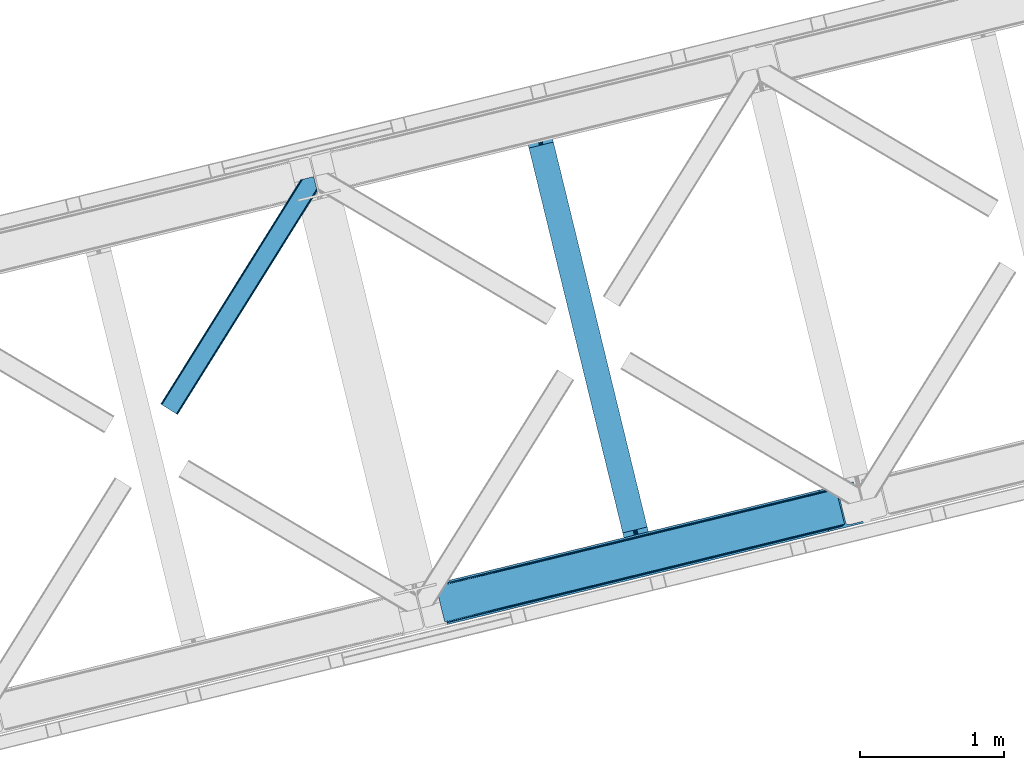
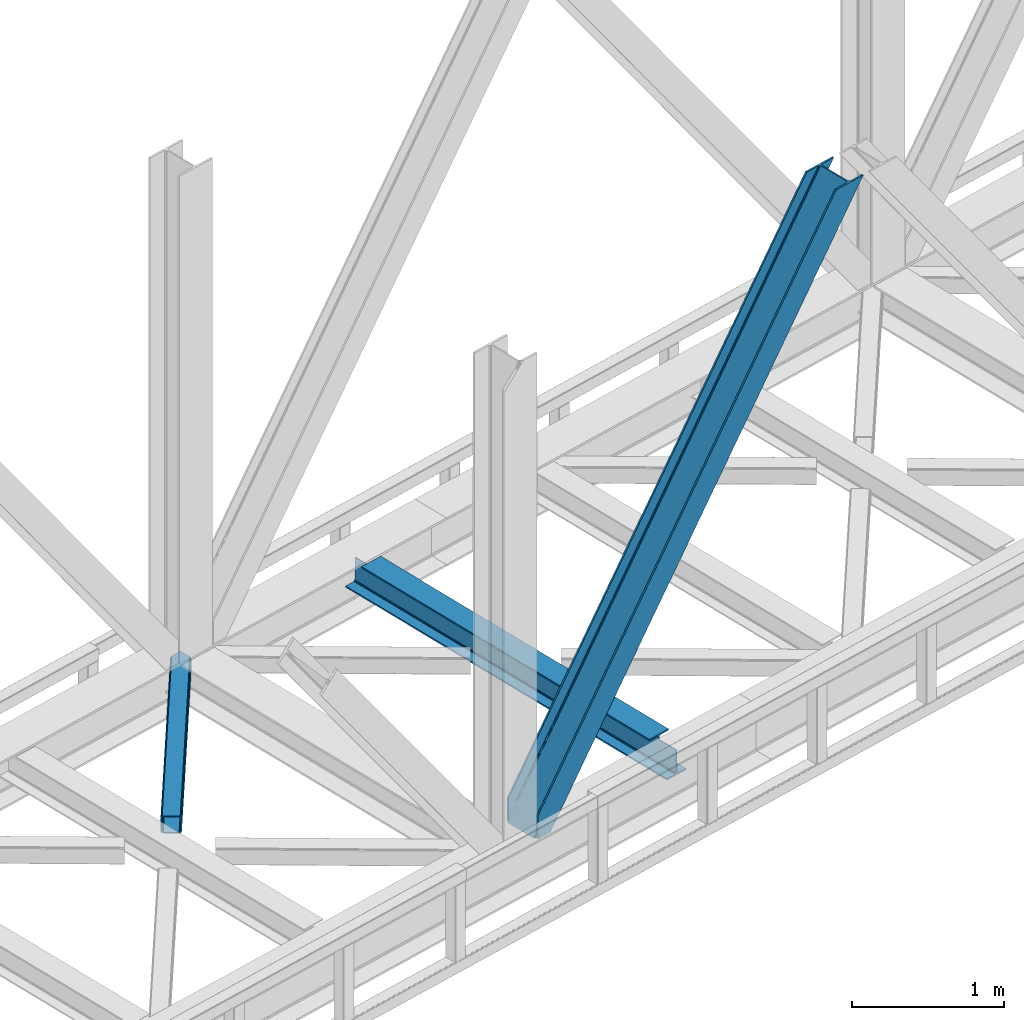
# One storey, part 63 of 92: 2 members, 1 beam.
"""IFC4 building model written with IfcOpenShell, lengths in millimetres."""

import ifcopenshell
import ifcopenshell.guid

model = None  # the IFC model being written
_history = None  # IfcOwnerHistory: only IFC2X3 demands one
_inside = {}  # id of a spatial element -> (the spatial element, [elements in it])
_under = {}  # id of a project, library or spatial element -> (it, [spatial elements below it])
_declared = {}  # id of a project -> (the project, [libraries it declares])
_typed = {}  # id of a type object -> (the type object, [elements of that type])
_made_of = {}  # id of a material, layer set ... -> (it, [elements and type objects made of it])


def new_model(schema):
    """Start an empty IFC model of exactly this schema.

    Asked for "IFC4X3", IfcOpenShell would pick the latest addendum, in which some entities
    have other attributes; the version numbers below select the first issue.
    IFC2X3 requires an IfcOwnerHistory on every rooted entity: one is made here for all.
    """
    global model, _history
    if schema == "IFC4X3":
        model = ifcopenshell.file(schema_version=(4, 3, 0, 0))
    else:
        model = ifcopenshell.file(schema=schema)
    _inside.clear()
    _under.clear()
    _declared.clear()
    _typed.clear()
    _made_of.clear()
    _history = None
    if model.schema == "IFC2X3":
        org = make("IfcOrganization", Name="unknown")
        user = make(
            "IfcPersonAndOrganization",
            ThePerson=make("IfcPerson", FamilyName="unknown"),
            TheOrganization=org,
        )
        app = make(
            "IfcApplication",
            ApplicationDeveloper=org,
            Version="unknown",
            ApplicationFullName="unknown",
            ApplicationIdentifier="unknown",
        )
        _history = make(
            "IfcOwnerHistory",
            OwningUser=user,
            OwningApplication=app,
            ChangeAction="ADDED",
            CreationDate=0,
        )
    return model


def make(cls, **values):
    """One entity of the class cls with the attributes given. An attribute that is None is left unset."""
    return model.create_entity(
        cls, **{name: value for name, value in values.items() if value is not None}
    )


def entity(cls, *values):
    """Any entity or typed value of the class cls, its attributes in the order of the schema. None: left unset."""
    e = model.create_entity(cls)
    for i, value in enumerate(values):
        if value is not None:
            e[i] = value
    return e


def rooted(cls, **values):
    """An entity with a GlobalId (a new one), such as an element, a storey or a relation."""
    return make(cls, GlobalId=ifcopenshell.guid.new(), OwnerHistory=_history, **values)


def si_unit(unit_type, name, prefix=None):
    """IfcSIUnit, for example si_unit("LENGTHUNIT", "METRE", prefix="MILLI")."""
    return make("IfcSIUnit", UnitType=unit_type, Prefix=prefix, Name=name)


def converted_unit(unit_type, name, factor, base, dimensions=None, offset=None):
    """IfcConversionBasedUnit, such as the inch: factor (a typed value) times the base unit."""
    return make(
        "IfcConversionBasedUnit"
        if offset is None
        else "IfcConversionBasedUnitWithOffset",
        ConversionOffset=offset,
        Dimensions=None
        if dimensions is None
        else entity("IfcDimensionalExponents", *dimensions),
        UnitType=unit_type,
        Name=name,
        ConversionFactor=make(
            "IfcMeasureWithUnit", ValueComponent=factor, UnitComponent=base
        ),
    )


def derived_unit(unit_type, elements):
    """IfcDerivedUnit: a product of units, each with its exponent."""
    return make(
        "IfcDerivedUnit",
        Elements=[
            make("IfcDerivedUnitElement", Unit=unit, Exponent=power)
            for unit, power in elements
        ],
        UnitType=unit_type,
    )


def assignment(units):
    """IfcUnitAssignment: the units of a project."""
    return None if units is None else make("IfcUnitAssignment", Units=units)


def point(xyz):
    """IfcCartesianPoint."""
    return None if xyz is None else make("IfcCartesianPoint", Coordinates=xyz)


def direction(xyz):
    """IfcDirection."""
    return None if xyz is None else make("IfcDirection", DirectionRatios=xyz)


def frame(location, z_axis=None, x_axis=None):
    """IfcAxis2Placement3D, a coordinate frame: its origin and axes. An axis left out is left unset."""
    return make(
        "IfcAxis2Placement3D",
        Location=point(location),
        Axis=direction(z_axis),
        RefDirection=direction(x_axis),
    )


def origin():
    """The frame at (0, 0, 0) with its axes left unset."""
    return frame((0.0, 0.0, 0.0))


def place(relative_to, where):
    """IfcLocalPlacement: puts the frame where relative to a parent placement (None: the world)."""
    return make(
        "IfcLocalPlacement", PlacementRelTo=relative_to, RelativePlacement=where
    )


def context(
    kind, dimensions, precision=None, world=None, true_north=None, identifier=None
):
    """IfcGeometricRepresentationContext, for example the 3D "Model" context."""
    return make(
        "IfcGeometricRepresentationContext",
        ContextIdentifier=identifier,
        ContextType=kind,
        CoordinateSpaceDimension=dimensions,
        Precision=precision,
        WorldCoordinateSystem=world,
        TrueNorth=true_north,
    )


def subcontext(parent, identifier, kind, view, scale=None):
    """IfcGeometricRepresentationSubContext, for example "Body" below "Model"."""
    return make(
        "IfcGeometricRepresentationSubContext",
        ContextIdentifier=identifier,
        ContextType=kind,
        ParentContext=parent,
        TargetScale=scale,
        TargetView=view,
    )


def project(units=None, contexts=None):
    """IfcProject with its units and contexts."""
    return rooted(
        "IfcProject",
        Name="project",
        RepresentationContexts=contexts,
        UnitsInContext=assignment(units),
    )


def spatial(cls, under=None, at=None, **own):
    """A site, building, storey or space (cls), placed at a placement, below another one or the project."""
    s = rooted(cls, ObjectPlacement=at, **own)
    if under is not None:
        _under.setdefault(under.id(), (under, []))[1].append(s)
    return s


def point_list(points):
    """IfcCartesianPointList2D or 3D."""
    cls = (
        "IfcCartesianPointList2D" if len(points[0]) == 2 else "IfcCartesianPointList3D"
    )
    return make(cls, CoordList=points)


def triangles(points, corners, closed=None, point_numbers=None):
    """IfcTriangulatedFaceSet: each triangle names its three corners, points numbered from 1."""
    return make(
        "IfcTriangulatedFaceSet",
        Coordinates=point_list(points),
        Closed=closed,
        CoordIndex=corners,
        PnIndex=point_numbers,
    )


def polygons(points, faces, closed=None, point_numbers=None):
    """IfcPolygonalFaceSet: a face is its outer loop, then its inner loops; points numbered from 1."""
    made = []
    for loops in faces:
        if len(loops) == 1:
            made.append(make("IfcIndexedPolygonalFace", CoordIndex=loops[0]))
        else:
            made.append(
                make(
                    "IfcIndexedPolygonalFaceWithVoids",
                    CoordIndex=loops[0],
                    InnerCoordIndices=loops[1:],
                )
            )
    return make(
        "IfcPolygonalFaceSet",
        Coordinates=point_list(points),
        Closed=closed,
        Faces=made,
        PnIndex=point_numbers,
    )


def shape(context_of_items, identifier, shape_type, items):
    """IfcShapeRepresentation: the items that make up one representation, for example the "Body"."""
    return make(
        "IfcShapeRepresentation",
        ContextOfItems=context_of_items,
        RepresentationIdentifier=identifier,
        RepresentationType=shape_type,
        Items=items,
    )


def material(Name=None, Category=None):
    """IfcMaterial."""
    return make("IfcMaterial", Name=Name, Category=Category)


def made_of(thing, what):
    """Note that an element or type object is made of a material, layer set ...; save() writes the relation."""
    if what is not None:
        _made_of.setdefault(what.id(), (what, []))[1].append(thing)
    return thing


def type_object(cls, material=None, **own):
    """A type object (cls), such as IfcWallType, which elements share."""
    return made_of(rooted(cls, **own), material)


def element(
    cls,
    number,
    at=None,
    inside=None,
    cuts=None,
    type_object=None,
    material=None,
    context=None,
    identifier="Body",
    shape_type=None,
    held_by="IfcProductDefinitionShape",
    body=None,
    shapes=None,
    **own,
):
    """One element of the class cls, such as IfcWall. Its Tag is "e" and its number.

    at: its placement. inside: the storey or other place that contains it. cuts: it is an
    opening in that element (IfcRelVoidsElement). A single representation is given by context,
    identifier, shape_type and body (its items); several are given by shapes. held_by: the class
    of the entity that holds the representations. save() writes the other relations.
    """
    e = rooted(cls, Tag="e%d" % number, ObjectPlacement=at, **own)
    if body is not None:
        shapes = [shape(context, identifier, shape_type, body)]
    if shapes is not None:
        e.Representation = make(held_by, Representations=shapes)
    if inside is not None:
        _inside.setdefault(inside.id(), (inside, []))[1].append(e)
    if cuts is not None:
        rooted(
            "IfcRelVoidsElement", RelatingBuildingElement=cuts, RelatedOpeningElement=e
        )
    if type_object is not None:
        _typed.setdefault(type_object.id(), (type_object, []))[1].append(e)
    return made_of(e, material)


def aggregate(whole, parts):
    """IfcRelAggregates: a whole, such as a stair, and the parts it consists of."""
    return rooted("IfcRelAggregates", RelatingObject=whole, RelatedObjects=parts)


def save(model, path):
    """Write the relations noted so far, then the file.

    IfcRelAggregates (storeys below a building ...), IfcRelContainedInSpatialStructure (elements
    in a storey), IfcRelDefinesByType, IfcRelAssociatesMaterial and IfcRelDeclares: one each for
    every whole, place, type object, material and project.
    """
    for whole, parts in _under.values():
        aggregate(whole, parts)
    for where, things in _inside.values():
        rooted(
            "IfcRelContainedInSpatialStructure",
            RelatedElements=things,
            RelatingStructure=where,
        )
    for kind, things in _typed.values():
        rooted("IfcRelDefinesByType", RelatedObjects=things, RelatingType=kind)
    for what, things in _made_of.values():
        rooted("IfcRelAssociatesMaterial", RelatedObjects=things, RelatingMaterial=what)
    for by, libraries in _declared.values():
        rooted("IfcRelDeclares", RelatingContext=by, RelatedDefinitions=libraries)
    model.write(path)


model = new_model("IFC4")

# Units and contexts
model_context = context("Model", 3, precision=0.01, world=origin(), true_north=direction((6.12303176911189e-17, 1.0)))
plan_context = context("Plan", 3, precision=0.01, world=origin(), true_north=direction((6.12303176911189e-17, 1.0)))
body_context = subcontext(model_context, "Body", "Model", "MODEL_VIEW")
ifc_project = project(units=[si_unit("LENGTHUNIT", "METRE", prefix="MILLI"), si_unit("AREAUNIT", "SQUARE_METRE"), si_unit("VOLUMEUNIT", "CUBIC_METRE"), converted_unit("PLANEANGLEUNIT", "DEGREE", entity("IfcRatioMeasure", 0.0174532925199433), si_unit("PLANEANGLEUNIT", "RADIAN"), dimensions=[0, 0, 0, 0, 0, 0, 0]), si_unit("MASSUNIT", "GRAM", prefix="KILO"), derived_unit("MASSDENSITYUNIT", [(si_unit("MASSUNIT", "GRAM", prefix="KILO"), 1), (si_unit("LENGTHUNIT", "METRE"), -3)]), derived_unit("MOMENTOFINERTIAUNIT", [(si_unit("LENGTHUNIT", "METRE"), 4)]), si_unit("TIMEUNIT", "SECOND"), si_unit("FREQUENCYUNIT", "HERTZ"), si_unit("THERMODYNAMICTEMPERATUREUNIT", "DEGREE_CELSIUS"), derived_unit("THERMALTRANSMITTANCEUNIT", [(si_unit("MASSUNIT", "GRAM", prefix="KILO"), 1), (si_unit("THERMODYNAMICTEMPERATUREUNIT", "KELVIN"), -1), (si_unit("TIMEUNIT", "SECOND"), -3)]), derived_unit("VOLUMETRICFLOWRATEUNIT", [(si_unit("LENGTHUNIT", "METRE"), 3), (si_unit("TIMEUNIT", "SECOND"), -1)]), derived_unit("MASSFLOWRATEUNIT", [(si_unit("MASSUNIT", "GRAM", prefix="KILO"), 1), (si_unit("TIMEUNIT", "SECOND"), -1)]), derived_unit("ROTATIONALFREQUENCYUNIT", [(si_unit("TIMEUNIT", "SECOND"), -1)]), si_unit("ELECTRICCURRENTUNIT", "AMPERE"), si_unit("ELECTRICVOLTAGEUNIT", "VOLT"), si_unit("POWERUNIT", "WATT"), si_unit("FORCEUNIT", "NEWTON", prefix="KILO"), si_unit("ILLUMINANCEUNIT", "LUX"), si_unit("LUMINOUSFLUXUNIT", "LUMEN"), si_unit("LUMINOUSINTENSITYUNIT", "CANDELA"), derived_unit("USERDEFINED", [(si_unit("MASSUNIT", "GRAM", prefix="KILO"), -1), (si_unit("LENGTHUNIT", "METRE"), -2), (si_unit("TIMEUNIT", "SECOND"), 3), (si_unit("LUMINOUSFLUXUNIT", "LUMEN"), 1)]), derived_unit("LINEARVELOCITYUNIT", [(si_unit("LENGTHUNIT", "METRE"), 1), (si_unit("TIMEUNIT", "SECOND"), -1)]), si_unit("PRESSUREUNIT", "PASCAL"), derived_unit("USERDEFINED", [(si_unit("LENGTHUNIT", "METRE"), -2), (si_unit("MASSUNIT", "GRAM", prefix="KILO"), 1), (si_unit("TIMEUNIT", "SECOND"), -2)]), derived_unit("LINEARFORCEUNIT", [(si_unit("MASSUNIT", "GRAM", prefix="KILO"), 1), (si_unit("LENGTHUNIT", "METRE"), 1), (si_unit("TIMEUNIT", "SECOND"), -2), (si_unit("LENGTHUNIT", "METRE"), -1)]), derived_unit("PLANARFORCEUNIT", [(si_unit("MASSUNIT", "GRAM", prefix="KILO"), 1), (si_unit("LENGTHUNIT", "METRE"), 1), (si_unit("TIMEUNIT", "SECOND"), -2), (si_unit("LENGTHUNIT", "METRE"), -2)])], contexts=[model_context, plan_context])

# Site, building, storey
site_placement = place(None, origin())
site = spatial("IfcSite", under=ifc_project, at=site_placement, CompositionType="ELEMENT")
building_placement = place(site_placement, origin())
building = spatial("IfcBuilding", under=site, at=building_placement, CompositionType="ELEMENT")
storey_placement = place(building_placement, frame((0.0, 0.0, 15900.0)))
storey = spatial("IfcBuildingStorey", under=building, at=storey_placement, Name="05", CompositionType="ELEMENT", Elevation=15900.0)

# Beam
ifc_material = material(Name="Metal painted (White)")
beam_type = type_object("IfcBeamType", PredefinedType="BEAM")
beam_placement = place(storey_placement, frame((-22569.05, 12291.3, 3441.0)))
element("IfcBeam", 1, at=beam_placement, inside=storey, type_object=beam_type, material=ifc_material, ObjectType="Steel Beam", PredefinedType="BEAM", context=body_context, shape_type="Tessellation", body=[
    polygons([(897.255335224839, 41.4445662733081, 11.000000000004), (897.255335224839, 41.4445662733081, 2.16573425859679e-12), (170.021610174761, 3024.83804881124, 2.16573425859679e-12), (170.021610174761, 3024.83804881124, 11.000000000004), (831.189795271217, 25.3403919499634, 11.000000000004), (103.956070221135, 3008.73387448789, 11.000000000004), (825.24104524992, 23.8903211957374, 12.2179274798217), (98.0073201998383, 3007.28380373367, 12.2179274798217), (820.197938493812, 22.6610105689172, 15.686291501017), (92.964213443734, 3006.05449310684, 15.686291501017), (816.828242290632, 21.8396114687075, 20.8770650821657), (89.5945172405538, 3005.23309400664, 20.8770650821657), (815.644962340954, 21.5511744621184, 27.0000000000047), (88.4112372908809, 3004.94465700005, 27.0000000000047), (81.6103728838758, 3003.28687434912, 27.0000000000047), (81.6103728838758, 3003.28687434912, 203.000000000006), (88.4112372908766, 3004.94465700005, 203.000000000006), (0.0, 2983.39348253793, 2.16573425859679e-12), (0.0, 2983.39348253793, 10.9999999999997), (66.0655399536129, 2999.49765686127, 11.000000000004), (72.0142899749184, 3000.9477276155, 12.2179274798217), (77.0573967310226, 3002.17703824232, 15.6862915010192), (80.4270929342029, 3002.99843734253, 20.8770650821657), (815.644962340954, 21.5511744621184, 203.000000000006), (808.844097933954, 19.8933918111854, 203.000000000006), (808.844097933949, 19.8933918111832, 27.0000000000047), (807.660817984281, 19.6049548045963, 20.8770650821657), (804.2911217811, 18.7835557043887, 15.6862915010192), (799.248015024996, 17.5542450775685, 12.2179274798217), (793.299265003691, 16.1041743233403, 11.000000000004), (727.233725050078, -2.16573425859679e-12, 10.9999999999997), (727.233725050078, -2.16573425859679e-12, 2.16573425859679e-12), (775.945201918152, 184.415062601688, 203.069791966819), (124.290390378902, 2857.75452019161, 203.000000000006), (124.513271168057, 2856.84017775719, 203.617301946336), (124.526185412576, 2856.78719778429, 217.000003693143), (775.799998669227, 185.010597404067, 217.000003676718), (775.800869277121, 185.007025963188, 204.00000679514), (769.234900753718, 182.385463974441, 203.006342981529), (769.012053092176, 183.299815969772, 203.617301946336), (768.999138847653, 183.352795942665, 217.000003693143), (117.725325591002, 2855.12939632289, 217.000003676718), (117.724454983108, 2855.13296776377, 204.00000679514), (117.580155394058, 2855.72494066435, 203.076120467494), (117.489525971914, 2856.09673754068, 203.000000000006), (776.983483393258, 185.29819437751, 223.122939328039), (780.352479801942, 186.122464201391, 228.313710402595), (785.395115205961, 187.353708426697, 231.782072735464), (791.343694076665, 188.804481281377, 232.999999602236), (857.409144942193, 204.909021065315, 232.999999283132), (857.407671605755, 204.915065042188, 243.999994005812), (687.386290701838, 163.469558245295, 243.999994827032), (687.387764038276, 163.463514268422, 233.000000104353), (753.453214903791, 179.568054052354, 232.999999785253), (759.402120032129, 181.017488520582, 231.782072861012), (764.445684539256, 182.244921343716, 228.313710479427), (767.816071449001, 183.063487001146, 223.12293937232), (116.541840866979, 2854.84179934945, 223.122939328039), (113.172844458296, 2854.01752952557, 228.313710402595), (108.130209054276, 2852.78628530026, 231.782072735464), (102.18163018356, 2851.33551244558, 232.999999602236), (36.1161793180448, 2835.23097266165, 232.999999283128), (36.1176526544823, 2835.22492868478, 243.999994005812), (206.139033558399, 2876.67043548167, 243.999994827032), (206.137560221961, 2876.67647945854, 233.000000104357), (140.072109356438, 2860.57193967461, 232.999999785253), (134.123204228108, 2859.12250520638, 231.782072861012), (129.079639720977, 2857.89507238325, 228.313710479427), (125.709252811232, 2857.07650672581, 223.12293937232)], [[[1, 2, 3, 4]], [[5, 1, 4, 6]], [[7, 5, 6, 8]], [[9, 7, 8, 10]], [[11, 9, 10, 12]], [[13, 11, 12, 14]], [[15, 16, 17, 14, 12, 10, 8, 6, 4, 3, 18, 19, 20, 21, 22, 23]], [[13, 24, 25, 26, 27, 28, 29, 30, 31, 32, 2, 1, 5, 7, 9, 11]], [[2, 32, 18, 3]], [[32, 31, 19, 18]], [[31, 30, 20, 19]], [[27, 26, 15, 23]], [[28, 27, 23, 22]], [[29, 28, 22, 21]], [[30, 29, 21, 20]], [[33, 24, 13, 14, 17, 34, 35, 36, 37, 38]], [[25, 39, 40, 41, 42, 43, 44, 16, 15, 26]], [[39, 25, 24, 33]], [[45, 34, 17, 16]], [[41, 40, 38, 37, 46, 47, 48, 49, 50, 51, 52, 53, 54, 55, 56, 57]], [[42, 58, 59, 60, 61, 62, 63, 64, 65, 66, 67, 68, 69, 36, 35, 43]], [[46, 37, 36, 69]], [[47, 46, 69, 68]], [[48, 47, 68, 67]], [[49, 48, 67, 66]], [[50, 49, 66, 65]], [[51, 50, 65, 64]], [[52, 51, 64, 63]], [[53, 52, 63, 62]], [[54, 53, 62, 61]], [[55, 54, 61, 60]], [[56, 55, 60, 59]], [[57, 56, 59, 58]], [[41, 57, 58, 42]]], closed=False),
])

# Members
member_type_1 = type_object("IfcMemberType", PredefinedType="BRACE")
member_1_placement = place(storey_placement, frame((-23178.5, 11819.31, 3695.0)))
element("IfcMember", 2, at=member_1_placement, inside=storey, type_object=member_type_1, ObjectType="Steel Vertical Brace", PredefinedType="BRACE", context=body_context, shape_type="Tessellation", body=[
    triangles([(58.5475891113274, 26.6239562988285, 0.0), (60.4404968261733, 18.8511749267582, 0.0), (59.1056945800774, 19.6697296142574, 0.80925292968459), (58.9708190917954, 18.4930572509766, 1.10690917968532), (64.089111328125, 19.7406555175785, 8.31577148437282), (64.089111328125, 19.7406555175785, 0.0), (522.907617187499, 126.716683959961, 658.855133056641), (68.3748962402351, 19.9243652343739, 14.8293273925774), (72.4072082519524, 18.4523620605469, 22.4381652832017), (524.586584472658, 133.136059570312, 656.552947998047), (73.9861816406265, 17.2873168945316, 26.4425720214822), (2834.75487670898, 696.264477539062, 3911.00081176758), (2834.77348022461, 703.35823059082, 3911.00081176758), (2385.95203857422, 593.953280639647, 3278.7231262207), (2386.50781860352, 586.999053955078, 3279.53005371094), (2831.44345092773, 689.4462890625, 3911.00081176758), (2384.82652587891, 580.578515625, 3281.83223876953), (2825.34149780274, 683.941973876952, 3911.00081176758), (2381.17326049805, 575.671838378907, 3285.27854003906), (2817.37919311523, 680.591015624999, 3911.00081176758), (2376.09450073242, 573.023162841797, 3289.34108276367), (514.170941162109, 119.160168457031, 666.36397705078), (519.249700927736, 121.80884399414, 662.301434326171), (77.0999450683594, 12.6189971923832, 50.6410949707024), (76.5674194335952, 13.9003143310547, 38.6743835449197), (75.4046997070327, 15.4258026123043, 33.1630920410134), (524.028479003908, 140.090286254883, 655.74602050781), (990.06514892578, 246.601226806641, 1312.29896850586), (989.509368896484, 253.556616210937, 1311.48971557617), (1455.54603881836, 360.067556762695, 1968.04266357422), (1454.99025878906, 367.021783447266, 1967.23341064453), (1921.02692871094, 473.533886718749, 2623.78635864258), (1920.47114868164, 480.48811340332, 2622.97710571289), (988.386181640624, 240.181851196288, 1314.598828125), (1453.8670715332, 353.647018432617, 1970.34484863281), (1919.34796142578, 467.113348388672, 2626.08854370117), (984.732916259767, 235.275173950195, 1318.04512939453), (1450.21380615234, 348.740341186523, 1973.78882446289), (1915.69469604492, 462.206671142578, 2629.53251953125), (979.651831054689, 232.626498413085, 1322.10767211914), (1445.13272094727, 346.091665649414, 1977.85369262695), (1910.61361083984, 459.557995605468, 2633.59738769531), (77.0999450683594, 12.6189971923832, 182.433050537107), (2723.82676391601, 657.786593627929, 3911.00081176758), (75.5698059082024, 15.5502136230461, 0.0), (77.3789978027344, 11.6585906982418, 0.0), (77.3789978027344, 11.6585906982418, 182.495837402341), (68.3748962402351, 19.9243652343739, 0.0), (72.4072082519524, 18.4523620605469, 0.0), (2726.9033203125, 645.157131958007, 3911.00081176758), (80.2206848144524, 0.0, 182.495837402341), (80.2206848144524, 0.0, 0.0), (191.327856445314, 27.0832305908207, 0.0), (2967.5537475586, 703.817504882813, 3911.00081176758), (1399.80990600586, 593.394012451172, 1967.23341064453), (2779.59312744141, 929.730459594726, 3911.00081176758), (2330.77168579102, 820.325509643555, 3278.7231262207), (1865.29079589844, 706.859179687499, 2622.97710571289), (934.329016113283, 479.927682495118, 1311.48971557617), (468.848126220702, 366.461352539061, 655.74602050781), (3.36723632812573, 252.996185302734, 0.0), (2964.47486572266, 716.448129272461, 3911.00081176758), (188.248974609374, 39.7138549804677, 0.0), (2870.92243652344, 693.643707275391, 3911.00081176758), (94.6965454101555, 16.9094329833988, 0.0), (2862.31133422851, 692.954214477539, 3911.00081176758), (86.083117675782, 16.2199401855469, 0.0), (2854.36065673828, 695.033157348633, 3911.00081176758), (78.1324401855454, 18.2977203369137, 0.0), (2848.28428344726, 699.561950683594, 3911.00081176758), (72.0560668945327, 22.8265136718746, 0.0), (2845.00308837891, 705.852264404297, 3911.00081176758), (68.7748718261719, 29.1168273925778, 0.0), (2789.8227355957, 932.223330688475, 3911.00081176758), (13.5945190429702, 255.489056396484, 0.0), (2789.84133911133, 939.318246459961, 3911.00081176758), (13.6131225585923, 262.582809448242, 0.0), (2793.15276489258, 946.136434936523, 3911.00081176758), (16.9245483398445, 269.400997924804, 0.0), (2799.25471801758, 951.639587402344, 3911.00081176758), (23.026501464843, 274.904150390625, 0.0), (2807.21702270508, 954.990545654297, 3911.00081176758), (30.9911315917961, 278.256271362305, 0.0), (2900.7694519043, 977.794967651367, 3911.00081176758), (124.543560791015, 301.060693359375, 0.0), (2897.69057006836, 990.425592041016, 3911.00081176758), (121.464678955079, 313.691317749022, 0.0), (2770.23323364258, 940.54956665039, 3911.00081176758), (2762.28255615234, 942.627346801757, 3911.00081176758), (2657.04014282226, 931.764056396483, 3911.00081176758), (2753.67145385742, 941.939016723632, 3911.00081176758), (2660.1190246582, 919.134594726562, 3911.00081176758), (2776.31193237305, 936.020773315429, 3911.00081176758), (10.3575073242173, 286.608087158203, 182.495837402341), (10.3575073242173, 286.608087158203, 0.0), (13.199194335939, 274.94949645996, 182.495837402341), (13.39453125, 273.966998291015, 182.433050537107), (1381.42730712891, 607.439666748047, 1977.85369262695), (1846.90819702148, 720.904833984374, 2633.59738769531), (2312.38908691406, 834.37116394043, 3289.34108276367), (915.94641723633, 493.973336791993, 1322.10767211914), (13.39453125, 273.966998291015, 50.6410949707024), (450.463201904298, 380.507006835936, 666.36397705078), (13.199194335939, 274.94949645996, 0.0), (13.5108032226563, 272.584524536132, 38.6743835449197), (13.3829040527344, 270.661386108399, 0.0), (13.3829040527344, 270.661386108399, 32.1678039550752), (12.4783081054702, 268.182467651366, 26.1867736816384), (11.9132263183601, 266.62907409668, 22.4381652832017), (11.9132263183601, 266.62907409668, 0.0), (9.00875244140479, 263.467639160155, 14.8293273925774), (9.00875244140479, 263.467639160155, 0.0), (5.11829223632958, 261.657284545898, 8.31577148437282), (5.11829223632958, 261.657284545898, 0.0), (1.47200317382885, 260.767803955077, 0.0), (461.697399902343, 377.819961547852, 658.855133056641), (456.193084716797, 380.493054199218, 662.301434326171), (466.143640136717, 372.892355346679, 656.552947998047), (0.662750244140625, 259.426025390625, 0.80925292968459), (0.0, 260.409686279296, 1.10690917968532), (2318.11664428711, 834.35721130371, 3285.27854003906), (2323.6186340332, 831.681793212891, 3281.83223876953), (2328.06487426758, 826.755349731446, 3279.53005371094), (921.676300048828, 493.959384155272, 1318.04512939453), (1387.15486450195, 607.425714111328, 1973.78882446289), (1852.63575439453, 720.892044067383, 2629.53251953125), (927.175964355469, 491.285128784179, 1314.598828125), (1392.65685424805, 604.750296020507, 1970.34484863281), (1858.13774414063, 718.216625976562, 2626.08854370117), (931.622204589843, 486.357522583008, 1312.29896850586), (1397.10309448242, 599.823852539063, 1968.04266357422), (1862.583984375, 713.290182495117, 2623.78635864258)], [[1, 2, 3], [4, 3, 2], [5, 4, 6], [2, 6, 4], [7, 8, 9], [10, 3, 8], [8, 7, 10], [9, 11, 7], [3, 4, 5], [5, 8, 3], [12, 13, 14], [14, 15, 12], [16, 12, 15], [15, 17, 16], [18, 16, 17], [17, 19, 18], [20, 18, 19], [19, 21, 20], [22, 23, 24], [25, 24, 23], [25, 7, 26], [25, 23, 7], [11, 26, 7], [10, 27, 3], [1, 3, 27], [28, 29, 10], [27, 10, 29], [30, 31, 28], [29, 28, 31], [32, 33, 31], [31, 30, 32], [15, 14, 33], [33, 32, 15], [34, 28, 7], [10, 7, 28], [35, 30, 34], [28, 34, 30], [36, 32, 35], [30, 35, 32], [17, 15, 36], [32, 36, 15], [37, 34, 7], [7, 23, 37], [38, 35, 34], [34, 37, 38], [39, 36, 35], [35, 38, 39], [19, 17, 36], [36, 39, 19], [40, 37, 22], [23, 22, 37], [41, 38, 40], [37, 40, 38], [42, 39, 41], [38, 41, 39], [21, 19, 42], [39, 42, 19], [41, 43, 44], [44, 21, 42], [21, 44, 20], [42, 41, 44], [43, 41, 40], [40, 22, 43], [24, 43, 22], [45, 11, 9], [45, 26, 11], [46, 25, 26], [46, 47, 24], [43, 24, 47], [24, 25, 46], [26, 45, 46], [48, 8, 5], [5, 6, 48], [49, 9, 8], [8, 48, 49], [9, 49, 45], [47, 44, 43], [50, 47, 51], [47, 50, 44], [52, 51, 46], [47, 46, 51], [50, 53, 54], [53, 50, 51], [52, 53, 51], [33, 55, 31], [13, 56, 57], [58, 14, 57], [55, 33, 58], [57, 14, 13], [58, 33, 14], [31, 59, 29], [59, 60, 27], [59, 31, 55], [61, 1, 60], [59, 27, 29], [60, 1, 27], [62, 54, 53], [53, 63, 62], [64, 62, 63], [63, 65, 64], [66, 64, 65], [65, 67, 66], [68, 66, 67], [67, 69, 68], [70, 68, 69], [69, 71, 70], [72, 70, 71], [71, 73, 72], [74, 72, 75], [73, 75, 72], [76, 74, 77], [75, 77, 74], [78, 76, 79], [77, 79, 76], [80, 78, 81], [79, 81, 78], [82, 80, 83], [81, 83, 80], [84, 82, 85], [83, 85, 82], [86, 84, 85], [85, 87, 86], [56, 13, 74], [16, 18, 66], [20, 50, 54], [44, 50, 20], [18, 20, 64], [13, 12, 70], [12, 16, 68], [88, 80, 89], [90, 91, 86], [91, 89, 82], [90, 92, 91], [88, 93, 78], [93, 56, 76], [74, 13, 72], [64, 66, 18], [70, 12, 68], [66, 68, 16], [70, 72, 13], [54, 64, 20], [54, 62, 64], [82, 89, 80], [78, 93, 76], [74, 76, 56], [78, 80, 88], [82, 86, 91], [86, 82, 84], [90, 87, 94], [90, 86, 87], [87, 95, 94], [96, 90, 94], [92, 96, 97], [96, 92, 90], [92, 97, 98], [98, 99, 92], [99, 100, 92], [91, 92, 100], [101, 98, 97], [97, 102, 103], [103, 101, 97], [104, 96, 94], [94, 95, 104], [104, 105, 102], [104, 106, 107], [107, 105, 104], [96, 104, 102], [102, 97, 96], [108, 106, 109], [108, 107, 106], [110, 109, 106], [109, 110, 111], [112, 111, 110], [111, 112, 113], [114, 113, 112], [75, 73, 61], [114, 75, 61], [114, 112, 75], [114, 61, 115], [79, 77, 110], [77, 75, 112], [106, 79, 110], [110, 77, 112], [73, 1, 61], [6, 73, 48], [1, 6, 2], [1, 73, 6], [48, 71, 49], [49, 71, 69], [73, 71, 48], [45, 49, 69], [104, 81, 79], [79, 106, 104], [95, 81, 104], [83, 95, 87], [87, 85, 83], [83, 81, 95], [45, 69, 46], [52, 67, 65], [46, 69, 67], [52, 46, 67], [65, 53, 52], [53, 65, 63], [116, 117, 105], [105, 107, 116], [118, 111, 113], [113, 119, 118], [118, 116, 108], [108, 109, 118], [109, 111, 118], [113, 120, 119], [107, 108, 116], [117, 103, 102], [102, 105, 117], [89, 91, 121], [100, 121, 91], [88, 89, 122], [121, 122, 89], [93, 88, 123], [122, 123, 88], [56, 93, 57], [123, 57, 93], [124, 101, 103], [103, 117, 124], [125, 98, 101], [101, 124, 125], [126, 99, 98], [98, 125, 126], [121, 100, 99], [99, 126, 121], [127, 124, 116], [117, 116, 124], [128, 125, 127], [124, 127, 125], [129, 126, 128], [125, 128, 126], [122, 121, 129], [126, 129, 121], [130, 127, 116], [116, 118, 130], [131, 128, 130], [127, 130, 128], [132, 129, 131], [128, 131, 129], [123, 122, 129], [129, 132, 123], [60, 118, 119], [119, 61, 60], [59, 130, 118], [118, 60, 59], [55, 131, 130], [130, 59, 55], [58, 132, 131], [131, 55, 58], [57, 123, 58], [132, 58, 123], [120, 113, 114], [114, 115, 120], [115, 61, 119], [119, 120, 115]]),
])
member_type_2 = type_object("IfcMemberType", PredefinedType="BRACE")
member_2_placement = place(storey_placement, frame((-25090.06, 13275.86, 3510.0)))
element("IfcMember", 3, at=member_2_placement, inside=storey, type_object=member_type_2, ObjectType="Steel Horizontal Brace", PredefinedType="BRACE", context=body_context, shape_type="Tessellation", body=[
    triangles([(933.019793701173, 1535.69230957031, 0.0), (967.780462646486, 1393.09171142578, 0.0), (14.8456054687485, 64.8704589843746, 0.0), (103.916912841796, 9.2680389404286, 0.0), (928.803771972656, 1552.99125366211, 5.49966430664063), (928.943298339844, 1552.41687011719, 5.20782165527635), (930.803649902344, 1544.78710327148, 1.33247680664135), (971.996484374999, 1375.79276733398, 5.49966430664063), (971.856958007811, 1376.36715087891, 5.20782165527635), (969.996606445311, 1383.99691772461, 1.33247680664135), (972.210424804689, 1375.53813171387, 5.85313110351854), (972.422039794921, 1375.28349609375, 6.20659790039281), (928.913067626952, 1553.56912536621, 5.74383544921875), (972.724346923827, 1375.53813171387, 6.35310058594041), (929.029339599609, 1554.1772277832, 5.9996337890625), (973.026654052734, 1375.79276733398, 6.49960327148438), (929.143286132814, 1554.78416748047, 6.25659484863354), (929.254907226561, 1555.36203918457, 6.49960327148438), (4.34857177734375, 71.4223846435543, 5.12526855468968), (1.13248901367115, 73.4315643310547, 10.8028289794929), (973.359191894531, 1630.84347839355, 10.8028289794929), (976.914788818358, 1631.70970458984, 6.49960327148438), (9.16455688476708, 68.415591430663, 1.33247680664135), (971.508142089842, 1630.39118041992, 17.5000946044929), (0.0, 74.1361724853505, 17.5000946044929), (1081.10145263672, 1548.91708374023, 6.49960327148438), (1056.20762329101, 1651.03759460449, 6.49960327148438), (971.508142089842, 1630.39118041992, 122.500662231447), (0.0, 74.1361724853505, 122.500662231447), (973.359191894531, 1630.84347839355, 129.197927856447), (1.13248901367115, 73.4315643310547, 129.197927856447), (978.633288574219, 1632.12828369141, 134.874325561526), (4.34857177734375, 71.4223846435543, 134.874325561526), (986.525830078124, 1634.05258483887, 138.667117309571), (9.16455688476708, 68.415591430663, 138.667117309571), (995.83921508789, 1636.32221374512, 139.999594116212), (14.8456054687485, 64.8704589843746, 139.999594116212), (118.760192871094, 0.0, 17.5000946044929), (117.630029296874, 0.705770874023074, 10.8028289794929), (1085.14306640625, 1551.25066223144, 10.9783996582046), (1087.41734619141, 1552.56453552246, 13.5003387451179), (109.595635986327, 5.7205810546875, 1.33247680664135), (114.41162109375, 2.71495056152344, 5.12526855468968), (1087.56849975586, 1551.93550415039, 17.5000946044929), (1081.77583007812, 1575.70149536133, 139.999594116212), (1063.00720825195, 1652.69563293457, 139.999594116212), (103.916912841796, 9.2680389404286, 139.999594116212), (1083.99429931641, 1566.60670166016, 138.667117309571), (109.595635986327, 5.7205810546875, 138.667117309571), (1085.87325439453, 1558.89670715332, 134.874325561526), (114.41162109375, 2.71495056152344, 134.874325561526), (1087.12899169922, 1553.74469604492, 129.197927856447), (117.630029296874, 0.705770874023074, 129.197927856447), (1087.56849975586, 1551.93550415039, 122.500662231447), (118.760192871094, 0.0, 122.500662231447), (1082.53857421875, 1566.77297058105, 12.1260040283232), (1083.96406860352, 1566.72413635254, 13.5003387451179), (1077.85048828125, 1569.98556518555, 8.3320495605476), (1074.6483581543, 1577.50138549805, 6.99957275390625), (1056.69364013672, 1651.1561920166, 6.99957275390625), (1005.57350463867, 1638.69532470703, 6.99957275390625), (20.784777832032, 61.1625457763657, 6.99957275390625), (97.9754150390618, 12.9736267089829, 6.99957275390625), (108.47244873047, 6.42053833007776, 12.1260040283232), (111.690856933594, 4.41252136230469, 17.8035644531265), (1084.81052856445, 1563.2510925293, 17.8035644531265), (103.656463623047, 9.42733154296729, 8.3320495605476), (1085.25236206055, 1561.44190063477, 24.4996673583992), (112.823345947265, 3.70675048827979, 24.4996673583992), (983.093481445314, 1633.21542663574, 17.8035644531265), (981.24010620117, 1632.76429138184, 24.4996673583992), (7.0693359375, 69.7248138427731, 17.8035644531265), (5.93917236327979, 70.4305847167961, 24.4996673583992), (988.365252685548, 1634.50139465332, 12.1260040283232), (10.2877441406235, 67.7156341552727, 12.1260040283232), (996.262445068358, 1636.42569580078, 8.3320495605476), (15.1037292480469, 64.7100036621086, 8.3320495605476), (981.24010620117, 1632.76429138184, 115.501089477541), (5.93917236327979, 70.4305847167961, 115.501089477541), (996.262445068358, 1636.42569580078, 131.667544555665), (1005.57350463867, 1638.69532470703, 133.000021362306), (1063.00720825195, 1652.69563293457, 133.000021362306), (988.365252685548, 1634.50139465332, 127.87475280762), (983.093481445314, 1633.21542663574, 122.196029663086), (20.784777832032, 61.1625457763657, 133.000021362306), (15.1037292480469, 64.7100036621086, 131.667544555665), (10.2877441406235, 67.7156341552727, 127.87475280762), (7.0693359375, 69.7248138427731, 122.196029663086), (108.47244873047, 6.42053833007776, 127.87475280762), (111.690856933594, 4.41252136230469, 122.196029663086), (112.823345947265, 3.70675048827979, 115.501089477541), (97.9754150390618, 12.9736267089829, 133.000021362306), (103.656463623047, 9.42733154296729, 131.667544555665), (1085.25236206055, 1561.44190063477, 115.501089477541), (1084.81052856445, 1563.2510925293, 122.196029663086), (1083.55479125976, 1568.40310363769, 127.87475280762), (1081.67583618164, 1576.11309814453, 131.667544555665), (1079.45969238281, 1585.20905456543, 133.000021362306)], [[1, 2, 3], [4, 3, 2], [1, 5, 2], [6, 5, 1], [1, 7, 6], [2, 5, 8], [8, 9, 2], [10, 2, 9], [11, 8, 5], [12, 11, 13], [14, 12, 15], [16, 14, 17], [17, 18, 16], [15, 17, 14], [13, 15, 12], [5, 13, 11], [17, 19, 18], [19, 17, 15], [13, 19, 15], [19, 13, 5], [5, 6, 19], [20, 21, 18], [18, 19, 20], [21, 22, 18], [19, 6, 7], [7, 1, 23], [3, 23, 1], [7, 23, 19], [24, 21, 20], [20, 25, 24], [18, 26, 16], [26, 18, 22], [27, 26, 22], [28, 24, 25], [25, 29, 28], [30, 28, 31], [29, 31, 28], [32, 30, 33], [31, 33, 30], [34, 32, 35], [33, 35, 32], [36, 34, 37], [35, 37, 34], [38, 39, 40], [40, 41, 38], [42, 10, 9], [39, 12, 16], [16, 40, 39], [16, 26, 40], [9, 39, 43], [9, 12, 39], [9, 43, 42], [2, 10, 4], [42, 4, 10], [41, 44, 38], [45, 36, 37], [36, 45, 46], [37, 47, 45], [48, 45, 47], [47, 49, 48], [50, 48, 49], [49, 51, 50], [52, 50, 51], [51, 53, 52], [54, 52, 53], [53, 55, 54], [44, 54, 38], [55, 38, 54], [56, 40, 26], [41, 40, 56], [56, 57, 41], [58, 26, 59], [26, 58, 56], [60, 59, 26], [59, 61, 62], [61, 59, 60], [62, 63, 59], [64, 65, 66], [66, 57, 64], [58, 59, 63], [63, 67, 58], [56, 58, 67], [67, 64, 56], [57, 56, 64], [68, 66, 65], [65, 69, 68], [70, 71, 72], [73, 72, 71], [74, 70, 75], [72, 75, 70], [76, 74, 77], [75, 77, 74], [61, 76, 62], [77, 62, 76], [71, 78, 73], [79, 73, 78], [34, 36, 80], [46, 81, 36], [81, 46, 82], [81, 80, 36], [83, 34, 80], [83, 32, 34], [32, 84, 30], [84, 32, 83], [28, 84, 78], [84, 28, 30], [61, 22, 76], [70, 74, 22], [74, 76, 22], [61, 60, 22], [71, 70, 24], [21, 24, 70], [28, 71, 24], [71, 28, 78], [70, 22, 21], [80, 81, 85], [85, 86, 80], [83, 80, 86], [86, 87, 83], [84, 83, 87], [87, 88, 84], [78, 84, 88], [88, 79, 78], [53, 89, 90], [91, 38, 55], [53, 90, 55], [53, 51, 89], [90, 91, 55], [89, 51, 49], [92, 47, 37], [47, 93, 49], [93, 47, 92], [93, 89, 49], [39, 64, 43], [69, 38, 91], [38, 65, 39], [65, 38, 69], [39, 65, 64], [4, 63, 3], [42, 43, 64], [64, 67, 42], [67, 63, 4], [4, 42, 67], [87, 35, 33], [37, 85, 92], [37, 86, 85], [86, 37, 35], [87, 86, 35], [79, 29, 25], [31, 88, 87], [33, 31, 87], [88, 31, 29], [79, 88, 29], [23, 75, 19], [3, 63, 62], [62, 77, 3], [77, 75, 23], [23, 3, 77], [20, 19, 75], [25, 73, 79], [72, 25, 20], [25, 72, 73], [72, 20, 75], [66, 41, 57], [54, 44, 68], [44, 66, 68], [68, 94, 54], [44, 41, 66], [95, 54, 94], [52, 54, 95], [50, 95, 96], [95, 50, 52], [96, 48, 50], [97, 48, 96], [97, 98, 45], [97, 45, 48], [98, 46, 45], [98, 82, 46], [81, 98, 85], [81, 82, 98], [92, 85, 98], [95, 94, 90], [91, 90, 94], [96, 95, 89], [90, 89, 95], [97, 96, 93], [89, 93, 96], [98, 97, 92], [93, 92, 97], [94, 68, 69], [69, 91, 94]]),
])

save(model, "model.ifc")
